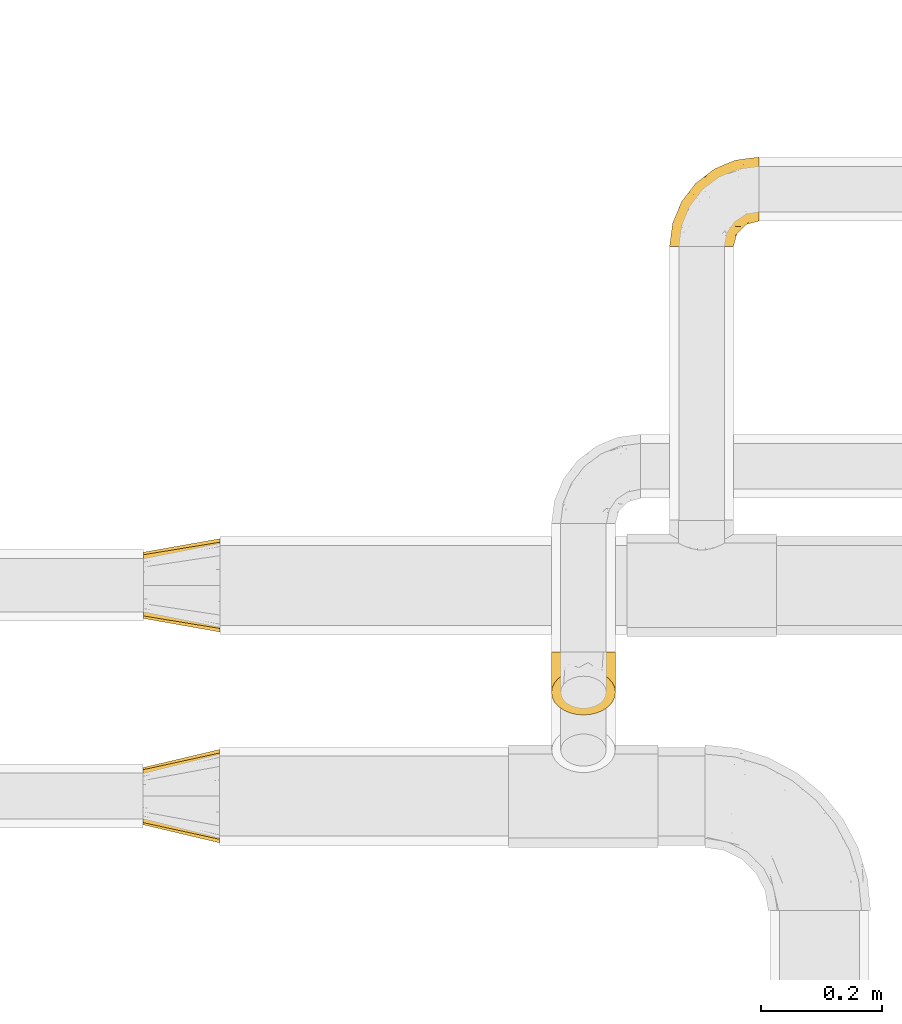
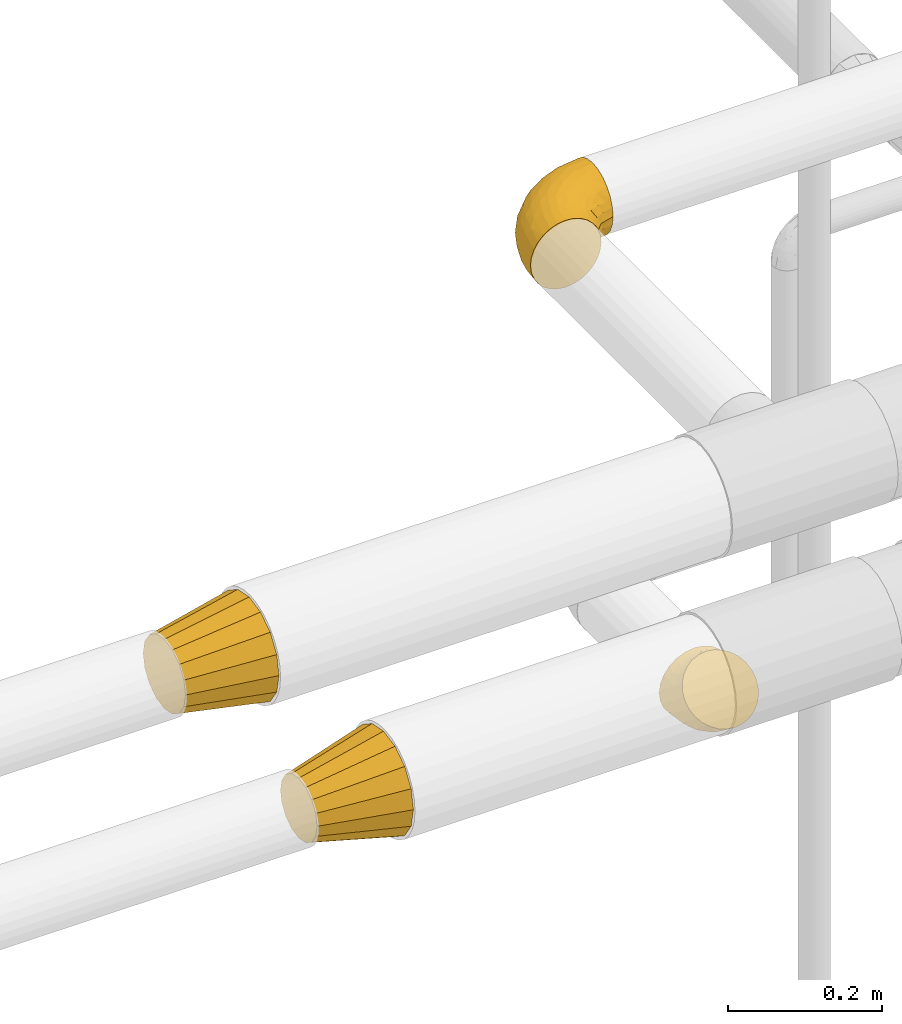
# One storey, part 135 of 827: 4 coverings.
"""IFC2X3 building model written with IfcOpenShell, lengths in millimetres."""

from ifc_helpers import new_model, entity, si_unit, converted_unit, derived_unit, direction, frame, origin, place, context, subcontext, project, spatial, faceted_brep, element, save


model = new_model("IFC2X3")

# Units and contexts
model_context = context("Model", 3, precision=0.01, world=origin(), true_north=direction((6.12303176911189e-17, 1.0)))
body_context = subcontext(model_context, "Body", "Model", "MODEL_VIEW")
ifc_project = project(units=[si_unit("LENGTHUNIT", "METRE", prefix="MILLI"), si_unit("AREAUNIT", "SQUARE_METRE"), si_unit("VOLUMEUNIT", "CUBIC_METRE"), converted_unit("PLANEANGLEUNIT", "DEGREE", entity("IfcRatioMeasure", 0.0174532925199433), si_unit("PLANEANGLEUNIT", "RADIAN"), dimensions=[0, 0, 0, 0, 0, 0, 0]), si_unit("MASSUNIT", "GRAM", prefix="KILO"), derived_unit("MASSDENSITYUNIT", [(si_unit("MASSUNIT", "GRAM", prefix="KILO"), 1), (si_unit("LENGTHUNIT", "METRE"), -3)]), derived_unit("MOMENTOFINERTIAUNIT", [(si_unit("LENGTHUNIT", "METRE"), 4)]), si_unit("TIMEUNIT", "SECOND"), si_unit("FREQUENCYUNIT", "HERTZ"), si_unit("THERMODYNAMICTEMPERATUREUNIT", "DEGREE_CELSIUS"), derived_unit("THERMALTRANSMITTANCEUNIT", [(si_unit("MASSUNIT", "GRAM", prefix="KILO"), 1), (si_unit("THERMODYNAMICTEMPERATUREUNIT", "KELVIN"), -1), (si_unit("TIMEUNIT", "SECOND"), -3)]), derived_unit("VOLUMETRICFLOWRATEUNIT", [(si_unit("LENGTHUNIT", "METRE"), 3), (si_unit("TIMEUNIT", "SECOND"), -1)]), derived_unit("MASSFLOWRATEUNIT", [(si_unit("MASSUNIT", "GRAM", prefix="KILO"), 1), (si_unit("TIMEUNIT", "SECOND"), -1)]), derived_unit("ROTATIONALFREQUENCYUNIT", [(si_unit("TIMEUNIT", "SECOND"), -1)]), si_unit("ELECTRICCURRENTUNIT", "AMPERE"), si_unit("ELECTRICVOLTAGEUNIT", "VOLT"), si_unit("POWERUNIT", "WATT"), si_unit("FORCEUNIT", "NEWTON", prefix="KILO"), si_unit("ILLUMINANCEUNIT", "LUX"), si_unit("LUMINOUSFLUXUNIT", "LUMEN"), si_unit("LUMINOUSINTENSITYUNIT", "CANDELA"), derived_unit("USERDEFINED", [(si_unit("MASSUNIT", "GRAM", prefix="KILO"), -1), (si_unit("LENGTHUNIT", "METRE"), -2), (si_unit("TIMEUNIT", "SECOND"), 3), (si_unit("LUMINOUSFLUXUNIT", "LUMEN"), 1)]), derived_unit("LINEARVELOCITYUNIT", [(si_unit("LENGTHUNIT", "METRE"), 1), (si_unit("TIMEUNIT", "SECOND"), -1)]), si_unit("PRESSUREUNIT", "PASCAL"), derived_unit("USERDEFINED", [(si_unit("LENGTHUNIT", "METRE"), -2), (si_unit("MASSUNIT", "GRAM", prefix="KILO"), 1), (si_unit("TIMEUNIT", "SECOND"), -2)]), derived_unit("LINEARFORCEUNIT", [(si_unit("MASSUNIT", "GRAM", prefix="KILO"), 1), (si_unit("LENGTHUNIT", "METRE"), 1), (si_unit("TIMEUNIT", "SECOND"), -2), (si_unit("LENGTHUNIT", "METRE"), -1)]), derived_unit("PLANARFORCEUNIT", [(si_unit("MASSUNIT", "GRAM", prefix="KILO"), 1), (si_unit("LENGTHUNIT", "METRE"), 1), (si_unit("TIMEUNIT", "SECOND"), -2), (si_unit("LENGTHUNIT", "METRE"), -2)])], contexts=[model_context])

# Site, building, storey
site_placement = place(None, origin())
site = spatial("IfcSite", under=ifc_project, at=site_placement, CompositionType="ELEMENT")
building_placement = place(site_placement, origin())
building = spatial("IfcBuilding", under=site, at=building_placement, CompositionType="ELEMENT")
storey_placement = place(building_placement, frame((0.0, 0.0, 28200.0)))
storey = spatial("IfcBuildingStorey", under=building, at=storey_placement, Name="08", CompositionType="ELEMENT", Elevation=28200.0)

# Coverings
covering_1_placement = place(storey_placement, frame((21584.81, 15310.65, 2745.29)))
element("IfcCovering", 1, at=covering_1_placement, inside=storey, Name=":ADSK_", ObjectType=":ADSK_", PredefinedType="INSULATION", context=body_context, shape_type="Brep", body=[
    faceted_brep([(2.92, 1.6, 66.44), (1.6, 1.6, 54.65), (2.93, 1.6, 42.84), (6.85, 1.6, 31.62), (13.18, 1.6, 21.56), (21.58, 1.6, 13.16), (31.64, 1.6, 6.84), (42.85, 1.6, 2.92), (54.65, 1.6, 1.6), (66.46, 1.6, 2.93), (77.67, 1.6, 6.85), (87.73, 1.6, 13.18), (96.13, 1.6, 21.58), (102.45, 1.6, 31.64), (106.37, 1.6, 42.85), (107.7, 1.6, 54.65), (106.36, 1.6, 66.46), (102.44, 1.6, 77.67), (96.11, 1.6, 87.73), (87.71, 1.6, 96.13), (77.65, 1.6, 102.45), (66.44, 1.6, 106.37), (54.65, 1.6, 107.7), (42.84, 1.6, 106.36), (31.62, 1.6, 102.44), (21.56, 1.6, 96.11), (13.16, 1.6, 87.71), (6.84, 1.6, 77.65), (149.65, 45.35, 40.91), (149.65, 50.65, 28.12), (149.65, 59.08, 17.13), (149.65, 70.07, 8.7), (149.65, 82.86, 3.4), (149.65, 96.6, 1.6), (149.65, 110.33, 3.4), (149.65, 123.12, 8.7), (149.65, 134.11, 17.13), (149.65, 142.54, 28.12), (149.65, 147.84, 40.91), (149.65, 149.65, 54.65), (149.65, 147.84, 68.38), (149.65, 142.54, 81.17), (149.65, 134.11, 92.16), (149.65, 123.12, 100.59), (149.65, 110.33, 105.89), (149.65, 96.6, 107.7), (149.65, 82.86, 105.89), (149.65, 70.07, 100.59), (149.65, 59.08, 92.16), (149.65, 50.65, 81.17), (149.65, 45.35, 68.38), (149.65, 43.55, 54.65), (123.27, 137.19, 85.53), (114.15, 141.79, 73.42), (92.97, 128.89, 83.77), (124.11, 146.54, 64.22), (111.33, 144.6, 54.65), (42.13, 69.77, 96.72), (56.83, 94.41, 93.36), (40.31, 87.22, 84.47), (61.55, 117.2, 71.37), (75.62, 129.81, 54.65), (44.96, 106.28, 54.65), (91.12, 101.45, 103.47), (109.83, 115.81, 100.91), (88.02, 109.14, 99.1), (119.19, 107.65, 105.43), (99.11, 93.36, 106.79), (27.97, 59.44, 89.81), (21.92, 63.23, 79.59), (12.94, 35.59, 81.29), (88.29, 132.3, 74.01), (95.35, 138.41, 64.14), (113.84, 126.28, 94.75), (6.64, 39.91, 54.65), (8.58, 37.44, 70.74), (33.39, 90.35, 68.3), (17.23, 65.0, 66.05), (61.99, 85.4, 100.73), (47.9, 26.66, 106.78), (37.72, 29.88, 103.6), (93.81, 78.45, 107.7), (107.05, 85.2, 107.7), (120.29, 91.95, 107.7), (73.26, 77.98, 106.07), (18.58, 29.55, 90.59), (29.72, 41.42, 97.43), (64.31, 111.13, 84.51), (82.84, 114.67, 93.3), (72.79, 57.43, 107.7), (83.3, 67.94, 107.7), (56.71, 14.64, 107.7), (59.29, 30.95, 107.7), (57.88, 52.13, 106.79), (66.04, 44.19, 107.7), (49.8, 60.12, 103.47), (21.43, 75.62, 54.65), (134.97, 94.27, 107.7), (108.79, 24.59, 76.99), (110.84, 34.69, 84.28), (101.53, 31.15, 91.11), (111.84, 75.18, 106.26), (119.98, 67.55, 102.6), (123.54, 79.36, 106.08), (134.54, 84.32, 106.56), (80.57, 40.81, 105.36), (69.55, 29.93, 106.74), (134.56, 70.24, 101.59), (128.67, 37.93, 54.65), (136.98, 40.15, 54.65), (133.56, 42.1, 67.71), (131.66, 55.38, 91.36), (117.75, 52.17, 94.33), (118.23, 44.32, 87.1), (110.55, 19.85, 65.84), (111.09, 14.26, 54.65), (113.32, 22.57, 54.65), (120.2, 34.17, 68.92), (105.95, 54.85, 100.82), (127.69, 44.63, 79.83), (139.88, 47.52, 77.13), (92.14, 59.1, 105.9), (93.82, 44.11, 101.53), (82.28, 53.21, 106.72), (130.86, 62.86, 97.75), (78.78, 20.58, 103.08), (67.58, 15.79, 106.39), (90.58, 27.67, 98.1), (90.23, 13.49, 95.02), (99.39, 18.04, 86.9), (105.17, 12.44, 74.42), (120.99, 30.25, 54.65), (104.59, 66.71, 105.28), (108.24, 42.52, 92.87), (131.66, 55.38, 17.93), (78.8, 20.57, 6.22), (133.57, 42.11, 41.58), (72.79, 57.43, 1.6), (82.27, 53.22, 2.57), (80.59, 40.81, 3.94), (110.55, 19.85, 43.46), (108.79, 24.58, 32.32), (120.2, 34.16, 40.38), (108.25, 42.5, 16.44), (106.06, 54.93, 8.47), (117.78, 52.13, 15.01), (90.6, 27.66, 11.21), (93.87, 44.12, 7.78), (93.81, 78.45, 1.6), (107.05, 85.2, 1.6), (111.89, 75.17, 3.04), (134.97, 94.27, 1.6), (134.54, 84.32, 2.73), (59.29, 30.95, 1.6), (66.04, 44.19, 1.6), (69.56, 29.98, 2.55), (104.56, 66.78, 3.98), (119.98, 67.55, 6.69), (134.56, 70.24, 7.7), (123.54, 79.36, 3.21), (90.25, 13.48, 14.28), (99.4, 18.03, 22.42), (110.83, 34.66, 25.02), (101.52, 31.14, 18.18), (105.18, 12.43, 34.89), (56.71, 14.64, 1.6), (139.89, 47.52, 32.17), (118.22, 44.28, 22.23), (67.6, 15.8, 2.91), (130.86, 62.86, 11.54), (83.3, 67.94, 1.6), (127.71, 44.64, 29.46), (92.12, 59.12, 3.38), (120.29, 91.95, 1.6), (92.97, 128.89, 25.52), (123.27, 137.19, 23.76), (113.84, 126.28, 14.54), (109.83, 115.81, 8.38), (124.03, 146.53, 45.07), (114.15, 141.79, 35.87), (98.04, 139.45, 45.14), (99.11, 93.36, 2.5), (47.9, 26.67, 2.51), (37.74, 29.87, 5.68), (49.8, 60.12, 5.82), (56.83, 94.41, 15.93), (42.16, 69.76, 12.54), (40.3, 87.19, 24.81), (57.88, 52.13, 2.5), (73.26, 77.98, 3.22), (119.19, 107.65, 3.86), (86.61, 131.74, 35.85), (27.99, 59.44, 19.47), (18.59, 29.54, 18.68), (21.92, 63.2, 29.68), (11.28, 27.9, 27.95), (33.39, 90.35, 40.99), (61.55, 117.2, 37.92), (29.73, 41.39, 11.85), (88.01, 109.14, 10.19), (62.08, 85.46, 8.55), (8.58, 37.43, 38.53), (82.84, 114.67, 15.99), (64.3, 111.12, 24.79), (91.12, 101.45, 5.82), (18.05, 65.16, 40.56)], [[[0, 1, 2, 3, 4, 5, 6, 7, 8, 9, 10, 11, 12, 13, 14, 15, 16, 17, 18, 19, 20, 21, 22, 23, 24, 25, 26, 27]], [[28, 29, 30, 31, 32, 33, 34, 35, 36, 37, 38, 39, 40, 41, 42, 43, 44, 45, 46, 47, 48, 49, 50, 51]], [[52, 53, 54]], [[55, 39, 56]], [[57, 58, 59]], [[60, 61, 62]], [[63, 64, 65]], [[66, 63, 67]], [[68, 69, 70]], [[53, 71, 54]], [[41, 40, 53]], [[53, 72, 71]], [[73, 42, 52]], [[42, 41, 52]], [[74, 0, 75]], [[69, 76, 77]], [[43, 73, 64]], [[45, 44, 66]], [[57, 78, 58]], [[23, 79, 80]], [[67, 81, 82, 83]], [[67, 84, 81]], [[24, 23, 80]], [[25, 85, 26]], [[86, 85, 25]], [[42, 73, 43]], [[0, 27, 75]], [[25, 24, 86]], [[70, 26, 85]], [[0, 74, 1]], [[68, 85, 86]], [[66, 64, 63]], [[60, 59, 87]], [[54, 87, 88]], [[76, 60, 62]], [[84, 89, 90, 81]], [[79, 22, 91, 92]], [[77, 74, 75]], [[93, 92, 94, 89]], [[80, 86, 24]], [[40, 55, 53]], [[76, 59, 60]], [[93, 84, 95]], [[76, 62, 96]], [[55, 72, 53]], [[70, 27, 26]], [[75, 70, 69]], [[78, 84, 63]], [[93, 79, 92]], [[95, 86, 80]], [[77, 76, 96]], [[59, 69, 68]], [[57, 68, 86]], [[68, 57, 59]], [[59, 58, 87]], [[76, 69, 59]], [[88, 87, 58]], [[87, 54, 71]], [[86, 95, 57]], [[78, 57, 95]], [[84, 78, 95]], [[78, 63, 65]], [[58, 78, 65]], [[54, 88, 73]], [[84, 93, 89]], [[79, 95, 80]], [[79, 93, 95]], [[22, 79, 23]], [[66, 83, 97, 45]], [[84, 67, 63]], [[83, 66, 67]], [[64, 44, 43]], [[64, 66, 44]], [[65, 73, 88]], [[53, 52, 41]], [[73, 52, 54]], [[73, 65, 64]], [[65, 88, 58]], [[39, 55, 40]], [[72, 55, 56]], [[56, 61, 72]], [[60, 72, 61]], [[72, 60, 71]], [[87, 71, 60]], [[27, 70, 75]], [[68, 70, 85]], [[74, 77, 96]], [[69, 77, 75]], [[98, 99, 100]], [[46, 45, 97]], [[101, 102, 103]], [[103, 104, 83]], [[105, 94, 106]], [[107, 103, 102]], [[108, 109, 51, 110]], [[111, 112, 113]], [[114, 115, 116]], [[47, 104, 107]], [[110, 117, 108]], [[49, 48, 111]], [[102, 118, 112]], [[119, 120, 111]], [[50, 49, 120]], [[121, 122, 118]], [[105, 123, 89]], [[124, 48, 107]], [[20, 19, 125]], [[121, 81, 90]], [[117, 119, 99]], [[21, 20, 126]], [[22, 21, 91]], [[105, 125, 127]], [[110, 51, 50]], [[19, 128, 125]], [[16, 15, 115]], [[129, 98, 100]], [[126, 91, 21]], [[128, 129, 127]], [[122, 123, 105]], [[114, 117, 98]], [[17, 16, 130]], [[18, 128, 19]], [[129, 18, 17]], [[125, 106, 126]], [[115, 114, 16]], [[130, 129, 17]], [[114, 98, 130]], [[117, 116, 131, 108]], [[99, 119, 113]], [[122, 121, 123]], [[92, 126, 106]], [[105, 127, 122]], [[132, 121, 118]], [[114, 130, 16]], [[129, 130, 98]], [[50, 120, 110]], [[129, 128, 18]], [[125, 128, 127]], [[125, 126, 20]], [[91, 126, 92]], [[105, 89, 94]], [[105, 106, 125]], [[94, 92, 106]], [[100, 122, 127]], [[118, 122, 133]], [[112, 118, 133]], [[132, 118, 102]], [[132, 102, 101]], [[81, 121, 132]], [[82, 103, 83]], [[132, 101, 81]], [[104, 47, 46]], [[124, 107, 102]], [[48, 47, 107]], [[113, 112, 133]], [[112, 111, 124]], [[99, 113, 133]], [[111, 113, 119]], [[99, 133, 100]], [[117, 99, 98]], [[122, 100, 133]], [[127, 129, 100]], [[103, 82, 101]], [[81, 101, 82]], [[112, 124, 102]], [[48, 124, 111]], [[104, 103, 107]], [[46, 97, 104]], [[111, 120, 49]], [[83, 104, 97]], [[110, 120, 119]], [[117, 110, 119]], [[116, 117, 114]], [[89, 123, 90]], [[90, 123, 121]], [[30, 29, 134]], [[11, 10, 135]], [[51, 109, 108, 136]], [[137, 138, 139]], [[140, 141, 142]], [[143, 144, 145]], [[146, 139, 147]], [[148, 149, 150]], [[151, 32, 152]], [[153, 154, 155]], [[156, 150, 157]], [[158, 157, 159]], [[108, 142, 136]], [[31, 158, 152]], [[160, 161, 12]], [[162, 163, 143]], [[140, 142, 116]], [[142, 141, 162]], [[14, 164, 140]], [[14, 140, 115]], [[9, 8, 165]], [[160, 12, 11]], [[141, 164, 161]], [[13, 12, 161]], [[14, 115, 15]], [[28, 166, 29]], [[135, 139, 146]], [[141, 163, 162]], [[135, 146, 160]], [[143, 167, 162]], [[29, 166, 134]], [[116, 142, 108, 131]], [[165, 153, 168]], [[10, 9, 168]], [[168, 135, 10]], [[138, 147, 139]], [[158, 169, 157]], [[14, 13, 164]], [[116, 115, 140]], [[145, 167, 143]], [[135, 160, 11]], [[168, 153, 155]], [[138, 137, 170]], [[157, 144, 156]], [[147, 144, 143]], [[161, 164, 13]], [[140, 164, 141]], [[142, 171, 136]], [[136, 171, 166]], [[161, 160, 146]], [[165, 168, 9]], [[155, 139, 135]], [[139, 154, 137]], [[168, 155, 135]], [[139, 155, 154]], [[144, 147, 172]], [[163, 147, 143]], [[156, 144, 172]], [[157, 169, 145]], [[172, 148, 156]], [[173, 159, 149]], [[159, 157, 150]], [[152, 159, 173]], [[159, 152, 158]], [[31, 30, 158]], [[169, 30, 134]], [[157, 145, 144]], [[167, 134, 171]], [[134, 167, 145]], [[171, 142, 162]], [[162, 167, 171]], [[163, 141, 161]], [[161, 146, 163]], [[147, 163, 146]], [[148, 150, 156]], [[149, 159, 150]], [[30, 169, 158]], [[145, 169, 134]], [[151, 33, 32]], [[31, 152, 32]], [[152, 173, 151]], [[28, 51, 136]], [[134, 166, 171]], [[28, 136, 166]], [[138, 170, 172]], [[147, 138, 172]], [[148, 172, 170]], [[174, 175, 176]], [[35, 34, 177]], [[178, 179, 180]], [[181, 173, 149, 148]], [[182, 183, 184]], [[185, 186, 187]], [[188, 189, 137]], [[190, 33, 151, 173]], [[191, 179, 174]], [[34, 190, 177]], [[39, 38, 178]], [[192, 193, 194]], [[4, 3, 195]], [[175, 179, 37]], [[38, 37, 179]], [[35, 176, 36]], [[196, 62, 197]], [[181, 190, 173]], [[37, 36, 175]], [[183, 6, 198]], [[189, 148, 170, 137]], [[185, 199, 200]], [[3, 2, 201]], [[202, 185, 203]], [[8, 7, 182]], [[200, 184, 186]], [[183, 7, 6]], [[181, 189, 204]], [[200, 189, 184]], [[5, 198, 6]], [[187, 203, 185]], [[195, 3, 201]], [[205, 196, 194]], [[62, 61, 197]], [[186, 198, 192]], [[180, 179, 191]], [[2, 1, 74]], [[198, 193, 192]], [[193, 5, 4]], [[194, 193, 195]], [[2, 74, 201]], [[5, 193, 198]], [[205, 74, 96]], [[188, 137, 154, 153]], [[62, 196, 96]], [[56, 178, 180]], [[198, 184, 183]], [[184, 188, 182]], [[203, 197, 191]], [[205, 194, 201]], [[187, 192, 194]], [[192, 187, 186]], [[194, 196, 187]], [[197, 187, 196]], [[197, 203, 187]], [[202, 174, 176]], [[200, 186, 185]], [[184, 198, 186]], [[199, 185, 202]], [[189, 200, 204]], [[174, 202, 203]], [[176, 177, 199]], [[189, 181, 148]], [[190, 181, 204]], [[190, 204, 177]], [[190, 34, 33]], [[188, 153, 182]], [[189, 188, 184]], [[182, 153, 165, 8]], [[183, 182, 7]], [[199, 177, 204]], [[35, 177, 176]], [[176, 175, 36]], [[179, 175, 174]], [[200, 199, 204]], [[176, 199, 202]], [[203, 191, 174]], [[180, 197, 61]], [[197, 180, 191]], [[61, 56, 180]], [[39, 178, 56]], [[38, 179, 178]], [[194, 195, 201]], [[4, 195, 193]], [[74, 205, 201]], [[96, 196, 205]]]),
])
covering_2_placement = place(storey_placement, frame((20712.9, 14320.9, 2720.89)))
element("IfcCovering", 2, at=covering_2_placement, inside=storey, Name=":ADSK_", ObjectType=":ADSK_", PredefinedType="INSULATION", context=body_context, shape_type="Brep", body=[
    faceted_brep([(0.0, 60.92, 122.98), (0.0, 70.01, 124.79), (0.0, 79.1, 126.6), (0.0, 88.18, 124.79), (0.0, 97.27, 122.98), (0.0, 104.98, 117.83), (0.0, 112.68, 112.68), (0.0, 117.83, 104.98), (0.0, 122.98, 97.27), (0.0, 124.79, 88.18), (0.0, 126.6, 79.1), (0.0, 124.79, 70.01), (0.0, 122.98, 60.92), (0.0, 117.83, 53.21), (0.0, 112.68, 45.51), (0.0, 104.98, 40.36), (0.0, 97.27, 35.21), (0.0, 88.18, 33.4), (0.0, 79.1, 31.6), (0.0, 70.01, 33.4), (0.0, 60.92, 35.21), (0.0, 53.21, 40.36), (0.0, 45.51, 45.51), (0.0, 40.36, 53.21), (0.0, 35.21, 60.92), (0.0, 33.4, 70.01), (0.0, 31.6, 79.1), (0.0, 33.4, 88.18), (0.0, 35.21, 97.27), (0.0, 40.36, 104.98), (0.0, 45.51, 112.68), (0.0, 53.21, 117.83), (127.0, 36.87, 142.3), (127.0, 24.29, 133.9), (127.0, 15.89, 121.32), (127.0, 7.49, 108.75), (127.0, 4.37, 93.04), (127.0, 1.6, 79.1), (127.0, 4.37, 65.15), (127.0, 7.49, 49.44), (127.0, 15.89, 36.87), (127.0, 24.29, 24.29), (127.0, 36.87, 15.89), (127.0, 49.44, 7.49), (127.0, 65.15, 4.37), (127.0, 79.1, 1.6), (127.0, 93.04, 4.37), (127.0, 108.75, 7.49), (127.0, 121.32, 15.89), (127.0, 133.9, 24.29), (127.0, 142.3, 36.87), (127.0, 150.7, 49.44), (127.0, 153.82, 65.15), (127.0, 156.6, 79.1), (127.0, 153.82, 93.04), (127.0, 150.7, 108.75), (127.0, 142.3, 121.32), (127.0, 133.9, 133.9), (127.0, 121.32, 142.3), (127.0, 108.75, 150.7), (127.0, 93.04, 153.82), (127.0, 79.1, 156.6), (127.0, 65.15, 153.82), (127.0, 49.44, 150.7)], [[[0, 1, 2, 3, 4, 5, 6, 7, 8, 9, 10, 11, 12, 13, 14, 15, 16, 17, 18, 19, 20, 21, 22, 23, 24, 25, 26, 27, 28, 29, 30, 31]], [[32, 33, 34, 35, 36, 37, 38, 39, 40, 41, 42, 43, 44, 45, 46, 47, 48, 49, 50, 51, 52, 53, 54, 55, 56, 57, 58, 59, 60, 61, 62, 63]], [[47, 46, 45, 18, 17, 16]], [[10, 53, 52, 51, 12, 11]], [[49, 48, 47, 16, 15, 14]], [[13, 12, 51, 50, 49, 14]], [[39, 38, 37, 26, 25, 24]], [[18, 45, 44, 43, 20, 19]], [[41, 40, 39, 24, 23, 22]], [[21, 20, 43, 42, 41, 22]], [[63, 62, 61, 2, 1, 0]], [[26, 37, 36, 35, 28, 27]], [[33, 32, 63, 0, 31, 30]], [[29, 28, 35, 34, 33, 30]], [[55, 54, 53, 10, 9, 8]], [[2, 61, 60, 59, 4, 3]], [[57, 56, 55, 8, 7, 6]], [[5, 4, 59, 58, 57, 6]]]),
])
covering_3_placement = place(storey_placement, frame((20713.57, 14670.7, 2720.9)))
element("IfcCovering", 3, at=covering_3_placement, inside=storey, Name=":ADSK_", ObjectType=":ADSK_", PredefinedType="INSULATION", context=body_context, shape_type="Brep", body=[
    faceted_brep([(0.0, 58.05, 129.91), (0.0, 68.57, 132.0), (0.0, 79.1, 134.1), (0.0, 89.62, 132.0), (0.0, 100.14, 129.91), (0.0, 109.06, 123.95), (0.0, 117.99, 117.99), (0.0, 123.95, 109.06), (0.0, 129.91, 100.14), (0.0, 132.0, 89.62), (0.0, 134.1, 79.1), (0.0, 132.0, 68.57), (0.0, 129.91, 58.05), (0.0, 123.95, 49.13), (0.0, 117.99, 40.2), (0.0, 109.06, 34.24), (0.0, 100.14, 28.28), (0.0, 89.62, 26.19), (0.0, 79.1, 24.1), (0.0, 68.57, 26.19), (0.0, 58.05, 28.28), (0.0, 49.13, 34.24), (0.0, 40.2, 40.2), (0.0, 34.24, 49.13), (0.0, 28.28, 58.05), (0.0, 26.19, 68.57), (0.0, 24.1, 79.1), (0.0, 26.19, 89.62), (0.0, 28.28, 100.14), (0.0, 34.24, 109.06), (0.0, 40.2, 117.99), (0.0, 49.13, 123.95), (127.0, 24.29, 133.9), (127.0, 15.89, 121.32), (127.0, 7.49, 108.75), (127.0, 4.48, 93.62), (127.0, 1.6, 79.1), (127.0, 4.48, 64.57), (127.0, 7.49, 49.44), (127.0, 15.89, 36.87), (127.0, 24.29, 24.29), (127.0, 36.87, 15.89), (127.0, 49.44, 7.49), (127.0, 64.57, 4.48), (127.0, 79.1, 1.6), (127.0, 93.62, 4.48), (127.0, 108.75, 7.49), (127.0, 121.32, 15.89), (127.0, 133.9, 24.29), (127.0, 142.3, 36.87), (127.0, 150.7, 49.44), (127.0, 153.71, 64.57), (127.0, 156.6, 79.1), (127.0, 153.71, 93.62), (127.0, 150.7, 108.75), (127.0, 142.3, 121.32), (127.0, 133.9, 133.9), (127.0, 121.32, 142.3), (127.0, 108.75, 150.7), (127.0, 93.62, 153.71), (127.0, 79.1, 156.6), (127.0, 64.57, 153.71), (127.0, 49.44, 150.7), (127.0, 36.87, 142.3)], [[[0, 1, 2, 3, 4, 5, 6, 7, 8, 9, 10, 11, 12, 13, 14, 15, 16, 17, 18, 19, 20, 21, 22, 23, 24, 25, 26, 27, 28, 29, 30, 31]], [[32, 33, 34, 35, 36, 37, 38, 39, 40, 41, 42, 43, 44, 45, 46, 47, 48, 49, 50, 51, 52, 53, 54, 55, 56, 57, 58, 59, 60, 61, 62, 63]], [[46, 45, 44, 18, 17, 16]], [[10, 52, 51, 50, 12, 11]], [[48, 47, 46, 16, 15, 14]], [[13, 12, 50, 49, 48, 14]], [[38, 37, 36, 26, 25, 24]], [[18, 44, 43, 42, 20, 19]], [[40, 39, 38, 24, 23, 22]], [[21, 20, 42, 41, 40, 22]], [[62, 61, 60, 2, 1, 0]], [[26, 36, 35, 34, 28, 27]], [[32, 63, 62, 0, 31, 30]], [[29, 28, 34, 33, 32, 30]], [[54, 53, 52, 10, 9, 8]], [[2, 60, 59, 58, 4, 3]], [[56, 55, 54, 8, 7, 6]], [[5, 4, 58, 57, 56, 6]]]),
])
covering_4_placement = place(storey_placement, frame((21388.91, 14533.05, 2545.35)))
element("IfcCovering", 4, at=covering_4_placement, inside=storey, Name=":ADSK_", ObjectType=":ADSK_", PredefinedType="INSULATION", context=body_context, shape_type="Brep", body=[
    faceted_brep([(54.65, 76.62, 119.98), (42.84, 75.68, 119.04), (31.62, 72.9, 116.26), (21.56, 68.43, 111.79), (13.16, 62.49, 105.85), (6.84, 55.38, 98.74), (2.92, 47.45, 90.81), (1.6, 39.11, 82.47), (2.93, 30.76, 74.12), (6.85, 22.83, 66.19), (13.18, 15.71, 59.08), (21.58, 9.77, 53.14), (31.64, 5.31, 48.67), (42.85, 2.53, 45.9), (54.65, 1.6, 44.96), (66.46, 2.54, 45.9), (77.67, 5.31, 48.68), (87.73, 9.78, 53.15), (96.13, 15.73, 59.09), (102.45, 22.84, 66.2), (106.37, 30.77, 74.13), (107.7, 39.11, 82.47), (106.36, 47.46, 90.82), (102.44, 55.39, 98.75), (96.11, 62.5, 105.86), (87.71, 68.44, 111.8), (77.65, 72.91, 116.27), (66.44, 75.68, 119.04), (68.38, 106.28, 105.89), (81.17, 106.28, 100.59), (92.16, 106.28, 92.16), (100.59, 106.28, 81.17), (105.89, 106.28, 68.38), (107.7, 106.28, 54.65), (105.89, 106.28, 40.91), (100.59, 106.28, 28.12), (92.16, 106.28, 17.13), (81.17, 106.28, 8.7), (68.38, 106.28, 3.4), (54.65, 106.28, 1.6), (40.91, 106.28, 3.4), (28.12, 106.28, 8.7), (17.13, 106.28, 17.13), (8.7, 106.28, 28.12), (3.4, 106.28, 40.91), (1.6, 106.28, 54.65), (3.4, 106.28, 68.38), (8.7, 106.28, 81.17), (17.13, 106.28, 92.16), (28.12, 106.28, 100.59), (40.91, 106.28, 105.89), (54.65, 106.28, 107.7), (17.98, 35.25, 36.8), (54.65, 67.96, 6.64), (23.07, 79.8, 14.58), (54.65, 32.26, 21.43), (40.45, 61.7, 10.5), (4.24, 63.6, 46.61), (5.7, 42.27, 53.56), (13.79, 63.31, 28.19), (8.23, 62.25, 37.28), (6.11, 84.86, 35.23), (37.78, 29.25, 26.45), (1.6, 81.69, 57.88), (1.6, 93.17, 56.37), (20.14, 54.48, 24.66), (27.08, 26.35, 34.31), (27.84, 51.61, 19.92), (10.41, 38.24, 45.64), (32.58, 80.62, 8.72), (1.6, 49.6, 74.42), (1.6, 58.78, 67.37), (1.6, 70.24, 62.63), (8.16, 89.95, 82.16), (4.17, 90.61, 72.54), (6.51, 78.07, 82.64), (3.36, 60.12, 82.55), (2.83, 70.53, 74.03), (8.06, 67.14, 92.07), (23.78, 85.96, 101.94), (13.97, 89.62, 91.02), (15.16, 75.23, 98.81), (35.68, 84.93, 109.52), (33.15, 96.09, 104.28), (43.74, 93.79, 108.41), (25.23, 77.02, 108.05), (54.65, 90.23, 110.89), (46.23, 84.14, 113.23), (24.78, 96.08, 99.52), (65.25, 94.73, 108.2), (73.59, 84.93, 109.53), (76.14, 96.08, 104.28), (94.11, 75.24, 98.82), (105.12, 90.61, 72.54), (102.77, 78.08, 82.66), (106.44, 77.29, 71.32), (84.51, 96.08, 99.52), (85.49, 85.96, 101.95), (107.7, 93.17, 56.37), (100.53, 93.96, 82.39), (95.3, 89.62, 91.05), (107.7, 81.69, 57.88), (101.22, 67.15, 92.08), (84.04, 77.03, 108.06), (105.93, 60.14, 82.56), (107.7, 70.24, 62.63), (107.7, 58.78, 67.37), (63.57, 84.73, 112.78), (107.7, 49.6, 74.42), (103.18, 84.86, 35.23), (71.52, 29.25, 26.45), (82.23, 26.36, 34.32), (91.32, 35.26, 36.81), (98.89, 38.25, 45.65), (101.06, 62.24, 37.28), (95.5, 63.35, 28.17), (86.22, 79.82, 14.58), (81.47, 51.62, 19.93), (76.72, 80.63, 8.72), (68.85, 61.73, 10.49), (103.6, 42.27, 53.58), (105.05, 63.6, 46.61)], [[[0, 1, 2, 3, 4, 5, 6, 7, 8, 9, 10, 11, 12, 13, 14, 15, 16, 17, 18, 19, 20, 21, 22, 23, 24, 25, 26, 27]], [[28, 29, 30, 31, 32, 33, 34, 35, 36, 37, 38, 39, 40, 41, 42, 43, 44, 45, 46, 47, 48, 49, 50, 51]], [[52, 11, 10]], [[40, 39, 53]], [[41, 54, 42]], [[53, 55, 56]], [[8, 57, 58]], [[59, 60, 61]], [[55, 13, 62]], [[59, 43, 42]], [[44, 63, 64, 45]], [[63, 44, 57]], [[43, 61, 44]], [[52, 65, 66]], [[54, 59, 42]], [[59, 65, 52]], [[62, 56, 55]], [[62, 67, 56]], [[52, 10, 68]], [[66, 12, 11]], [[66, 62, 12]], [[13, 55, 14]], [[54, 67, 65]], [[69, 54, 41]], [[40, 56, 69]], [[62, 66, 67]], [[68, 10, 9]], [[8, 7, 70, 71]], [[57, 71, 72, 63]], [[57, 8, 71]], [[59, 52, 68]], [[58, 68, 9]], [[60, 57, 61]], [[40, 53, 56]], [[52, 66, 11]], [[62, 13, 12]], [[40, 69, 41]], [[67, 54, 69]], [[67, 69, 56]], [[8, 58, 9]], [[60, 58, 57]], [[59, 61, 43]], [[57, 44, 61]], [[59, 68, 60]], [[58, 60, 68]], [[54, 65, 59]], [[66, 65, 67]], [[73, 48, 47]], [[63, 74, 64]], [[47, 74, 73]], [[74, 75, 73]], [[70, 76, 71]], [[75, 77, 78]], [[79, 80, 81]], [[79, 82, 83]], [[84, 51, 50]], [[49, 83, 50]], [[75, 81, 80]], [[4, 78, 5]], [[2, 85, 3]], [[82, 84, 83]], [[78, 77, 76]], [[77, 63, 72, 71]], [[85, 81, 3]], [[76, 6, 5]], [[78, 76, 5]], [[76, 70, 6]], [[77, 74, 63]], [[74, 46, 64]], [[47, 46, 74]], [[86, 87, 0]], [[86, 84, 87]], [[1, 82, 2]], [[3, 81, 4]], [[80, 88, 48]], [[79, 85, 82]], [[83, 88, 79]], [[70, 7, 6]], [[4, 81, 78]], [[81, 75, 78]], [[76, 77, 71]], [[83, 49, 88]], [[1, 87, 82]], [[51, 84, 86]], [[50, 83, 84]], [[82, 87, 84]], [[0, 87, 1]], [[82, 85, 2]], [[81, 85, 79]], [[48, 88, 49]], [[80, 79, 88]], [[46, 45, 64]], [[75, 80, 73]], [[73, 80, 48]], [[74, 77, 75]], [[89, 90, 91]], [[25, 24, 92]], [[86, 89, 51]], [[93, 94, 95]], [[96, 91, 97]], [[91, 29, 28]], [[93, 98, 32]], [[30, 99, 31]], [[93, 32, 31]], [[30, 29, 96]], [[92, 100, 97]], [[31, 99, 93]], [[93, 95, 101]], [[92, 94, 100]], [[26, 90, 27]], [[24, 102, 92]], [[26, 103, 90]], [[22, 104, 23]], [[92, 97, 103]], [[105, 101, 95, 106]], [[91, 96, 29]], [[103, 26, 25]], [[30, 100, 99]], [[104, 102, 23]], [[107, 90, 89]], [[102, 24, 23]], [[106, 104, 108]], [[104, 22, 108]], [[94, 93, 99]], [[102, 104, 94]], [[22, 21, 108]], [[107, 0, 27]], [[94, 92, 102]], [[95, 104, 106]], [[89, 91, 28]], [[97, 91, 90]], [[51, 89, 28]], [[89, 86, 107]], [[0, 107, 86]], [[27, 90, 107]], [[92, 103, 25]], [[90, 103, 97]], [[97, 100, 96]], [[30, 96, 100]], [[98, 93, 101]], [[98, 33, 32]], [[94, 99, 100]], [[104, 95, 94]], [[35, 34, 109]], [[110, 111, 16]], [[34, 33, 98, 101]], [[112, 113, 18]], [[114, 115, 109]], [[116, 115, 117]], [[39, 38, 53]], [[117, 118, 116]], [[110, 119, 117]], [[115, 116, 36]], [[35, 115, 36]], [[37, 116, 118]], [[118, 117, 119]], [[19, 120, 20]], [[121, 101, 105, 106]], [[112, 111, 117]], [[20, 106, 108, 21]], [[36, 116, 37]], [[112, 18, 17]], [[53, 38, 119]], [[117, 115, 112]], [[121, 34, 101]], [[118, 38, 37]], [[113, 19, 18]], [[119, 110, 55]], [[111, 17, 16]], [[15, 14, 55]], [[15, 55, 110]], [[120, 19, 113]], [[111, 110, 117]], [[119, 55, 53]], [[15, 110, 16]], [[111, 112, 17]], [[20, 121, 106]], [[112, 115, 113]], [[109, 115, 35]], [[38, 118, 119]], [[114, 120, 113]], [[20, 120, 121]], [[34, 121, 109]], [[109, 121, 114]], [[120, 114, 121]], [[113, 115, 114]]]),
])

save(model, "model.ifc")
